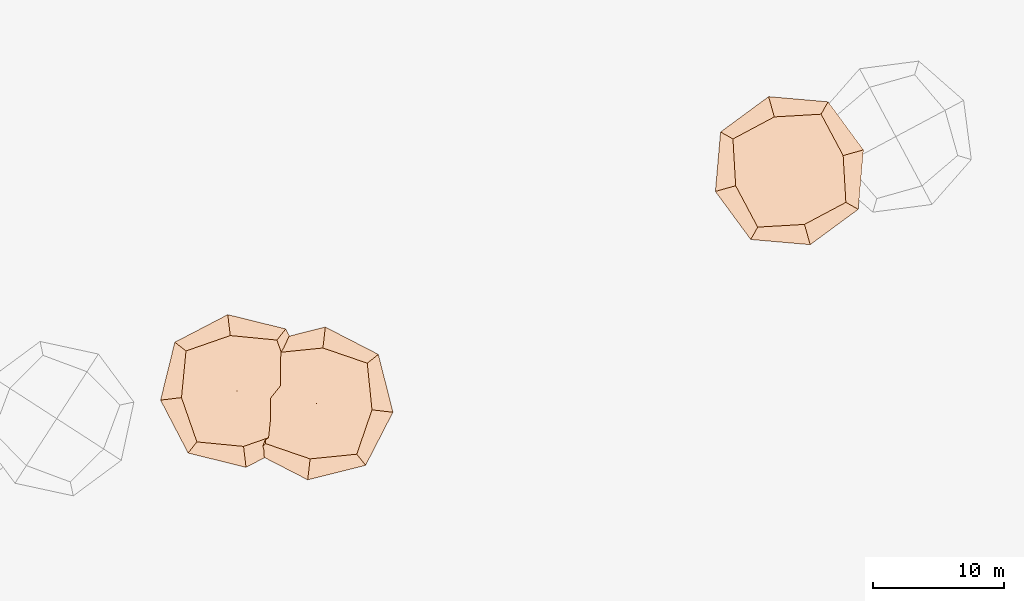
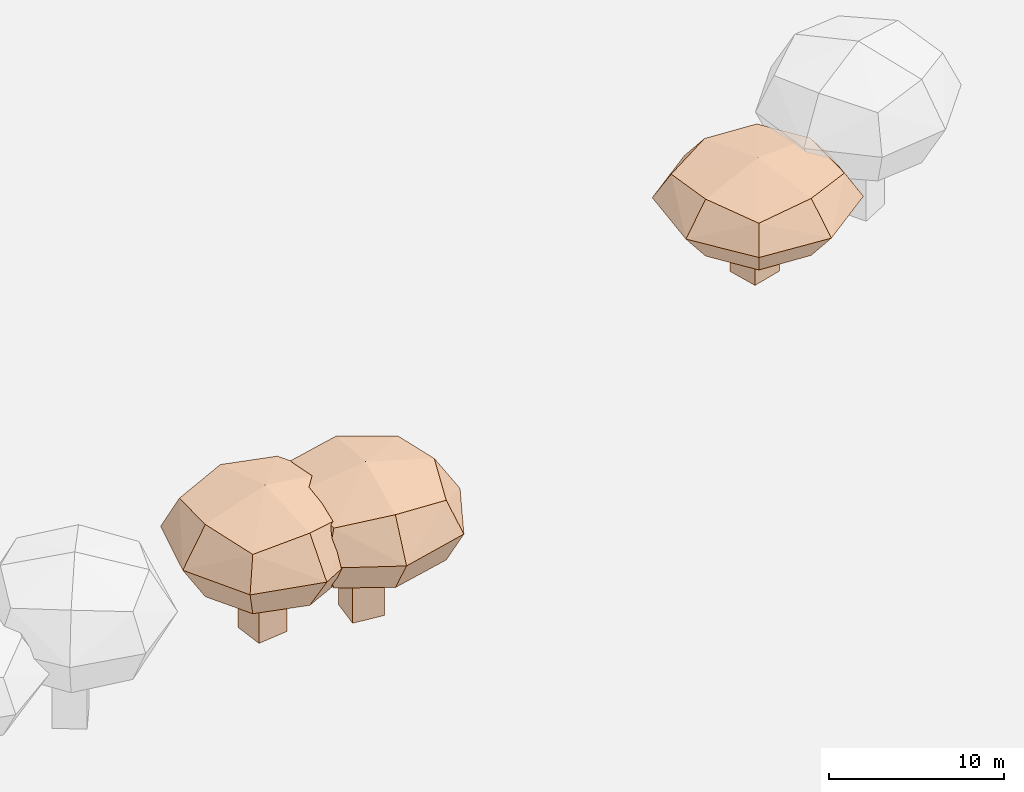
# Not in any storey, part 16 of 92: 3 geographic elements.
"""IFC4 model written with IfcOpenShell, lengths in metres."""

from ifc_helpers import new_model, si_unit, origin_with_axes, place, context, subcontext, project, spatial, triangles, material, element, save


model = new_model("IFC4")

# Units and contexts
model_context = context("Model", 3, precision=1e-05, world=origin_with_axes())
body_context = subcontext(model_context, "Body", "Model", "MODEL_VIEW")
ifc_project = project(units=[si_unit("VOLUMEUNIT", "CUBIC_METRE"), si_unit("LENGTHUNIT", "METRE"), si_unit("AREAUNIT", "SQUARE_METRE")], contexts=[model_context])

# Site
site_placement = place(None, origin_with_axes())
site = spatial("IfcSite", under=ifc_project, at=site_placement)

# Geographic elements
ifc_material = material(Name="tree")
geographic_element_1_placement = place(site_placement, origin_with_axes())
element("IfcGeographicElement", 1, at=geographic_element_1_placement, inside=site, material=ifc_material, Name="cw_instances_tree_207", context=body_context, shape_type="Tessellation", body=[
    triangles([(44.759325062805495, -633.7780550912393, 5.902577090570776), (44.759325062805495, -633.7780550912393, 5.902577090570776), (44.759325062805495, -633.7780550912393, 5.902577090570776), (44.759325062805495, -633.7780550912393, 0.0), (44.759325062805495, -633.7780550912393, 0.0), (44.759325062805495, -633.7780550912393, 0.0), (46.745150937712, -633.5403670718697, 5.902577090570776), (46.745150937712, -633.5403670718697, 5.902577090570776), (46.745150937712, -633.5403670718697, 5.902577090570776), (46.745150937712, -633.5403670718697, 0.0), (46.745150937712, -633.5403670718697, 0.0), (46.745150937712, -633.5403670718697, 0.0), (44.99701308217506, -635.7638809661458, 5.902577090570776), (44.99701308217506, -635.7638809661458, 5.902577090570776), (44.99701308217506, -635.7638809661458, 5.902577090570776), (44.99701308217506, -635.7638809661458, 0.0), (44.99701308217506, -635.7638809661458, 0.0), (44.99701308217506, -635.7638809661458, 0.0), (46.98283895708156, -635.5261929467763, 5.902577090570776), (46.98283895708156, -635.5261929467763, 5.902577090570776), (46.98283895708156, -635.5261929467763, 5.902577090570776), (46.98283895708156, -635.5261929467763, 0.0), (46.98283895708156, -635.5261929467763, 0.0), (46.98283895708156, -635.5261929467763, 0.0), (42.00949515011123, -631.839867910236, 8.792273568300379), (42.00949515011123, -631.839867910236, 8.792273568300379), (42.00949515011123, -631.839867910236, 8.792273568300379), (42.00949515011123, -631.839867910236, 8.792273568300379), (42.00949515011123, -631.839867910236, 8.792273568300379), (42.00949515011123, -631.839867910236, 8.792273568300379), (42.009494644990454, -631.839867728982, 4.6604697701730045), (42.009494644990454, -631.839867728982, 4.6604697701730045), (42.009494644990454, -631.839867728982, 4.6604697701730045), (42.009494644990454, -631.839867728982, 4.6604697701730045), (42.009494644990454, -631.839867728982, 4.6604697701730045), (42.009494644990454, -631.839867728982, 4.6604697701730045), (48.959884025596814, -631.0079598026128, 8.792273568300379), (48.959884025596814, -631.0079598026128, 8.792273568300379), (48.959884025596814, -631.0079598026128, 8.792273568300379), (48.959884025596814, -631.0079598026128, 8.792273568300379), (48.959884025596814, -631.0079598026128, 8.792273568300379), (48.959884025596814, -631.0079598026128, 8.792273568300379), (48.959884025596814, -631.0079598026128, 4.6604697701730045), (48.959884025596814, -631.0079598026128, 4.6604697701730045), (48.959884025596814, -631.0079598026128, 4.6604697701730045), (48.959884025596814, -631.0079598026128, 4.6604697701730045), (48.959884025596814, -631.0079598026128, 4.6604697701730045), (48.959884025596814, -631.0079598026128, 4.6604697701730045), (42.84140265692725, -638.7902578244857, 8.792273568300379), (42.84140265692725, -638.7902578244857, 8.792273568300379), (42.84140265692725, -638.7902578244857, 8.792273568300379), (42.84140265692725, -638.7902578244857, 8.792273568300379), (42.84140265692725, -638.7902578244857, 8.792273568300379), (42.84140265692725, -638.7902578244857, 8.792273568300379), (42.84140259988212, -638.7902573478874, 4.6604697701730045), (42.84140259988212, -638.7902573478874, 4.6604697701730045), (42.84140259988212, -638.7902573478874, 4.6604697701730045), (42.84140259988212, -638.7902573478874, 4.6604697701730045), (42.84140259988212, -638.7902573478874, 4.6604697701730045), (42.84140259988212, -638.7902573478874, 4.6604697701730045), (49.79179227583271, -637.958349869594, 8.792273568300379), (49.79179227583271, -637.958349869594, 8.792273568300379), (49.79179227583271, -637.958349869594, 8.792273568300379), (49.79179227583271, -637.958349869594, 8.792273568300379), (49.79179227583271, -637.958349869594, 8.792273568300379), (49.79179227583271, -637.958349869594, 8.792273568300379), (49.79179203753361, -637.9583498981166, 4.6604697701730045), (49.79179203753361, -637.9583498981166, 4.6604697701730045), (49.79179203753361, -637.9583498981166, 4.6604697701730045), (49.79179203753361, -637.9583498981166, 4.6604697701730045), (49.79179203753361, -637.9583498981166, 4.6604697701730045), (49.79179203753361, -637.9583498981166, 4.6604697701730045), (46.40774785609414, -639.1358431660274, 4.207757367838146), (46.40774785609414, -639.1358431660274, 4.207757367838146), (46.40774785609414, -639.1358431660274, 4.207757367838146), (46.40774785609414, -639.1358431660274, 4.207757367838146), (41.66390955439911, -635.4062130894682, 4.207757367838146), (41.66390955439911, -635.4062130894682, 4.207757367838146), (41.66390955439911, -635.4062130894682, 4.207757367838146), (41.66390955439911, -635.4062130894682, 4.207757367838146), (41.15680523362647, -631.1694792223673, 6.726372023391338), (41.15680523362647, -631.1694792223673, 6.726372023391338), (41.15680523362647, -631.1694792223673, 6.726372023391338), (41.15680523362647, -631.1694792223673, 6.726372023391338), (50.644481743053376, -638.6287388428779, 6.726372023391338), (50.644481743053376, -638.6287388428779, 6.726372023391338), (50.644481743053376, -638.6287388428779, 6.726372023391338), (50.644481743053376, -638.6287388428779, 6.726372023391338), (49.63027344814473, -630.1552700499772, 6.726372023391338), (49.63027344814473, -630.1552700499772, 6.726372023391338), (49.63027344814473, -630.1552700499772, 6.726372023391338), (49.63027344814473, -630.1552700499772, 6.726372023391338), (42.1710138823024, -639.6429470161439, 6.726372023391338), (42.1710138823024, -639.6429470161439, 6.726372023391338), (42.1710138823024, -639.6429470161439, 6.726372023391338), (42.1710138823024, -639.6429470161439, 6.726372023391338), (50.137377824774056, -634.3920043837471, 9.244985616480589), (50.137377824774056, -634.3920043837471, 9.244985616480589), (50.137377824774056, -634.3920043837471, 9.244985616480589), (50.137377824774056, -634.3920043837471, 9.244985616480589), (45.39353899522512, -630.6623744408677, 9.244987003586289), (45.39353899522512, -630.6623744408677, 9.244987003586289), (45.39353899522512, -630.6623744408677, 9.244987003586289), (45.39353899522512, -630.6623744408677, 9.244987003586289), (50.137377364047175, -634.3920044892495, 4.207757367838146), (50.137377364047175, -634.3920044892495, 4.207757367838146), (50.137377364047175, -634.3920044892495, 4.207757367838146), (50.137377364047175, -634.3920044892495, 4.207757367838146), (46.40774781637762, -639.1358431707811, 9.244985616480589), (46.40774781637762, -639.1358431707811, 9.244985616480589), (46.40774781637762, -639.1358431707811, 9.244985616480589), (46.40774781637762, -639.1358431707811, 9.244985616480589), (41.66390955083379, -635.4062130596808, 9.244987003586289), (41.66390955083379, -635.4062130596808, 9.244987003586289), (41.66390955083379, -635.4062130596808, 9.244987003586289), (41.66390955083379, -635.4062130596808, 9.244987003586289), (45.39353911065658, -630.6623749004061, 4.207757367838146), (45.39353911065658, -630.6623749004061, 4.207757367838146), (45.39353911065658, -630.6623749004061, 4.207757367838146), (45.39353911065658, -630.6623749004061, 4.207757367838146), (45.90064331185806, -634.8991088623899, 10.195047334996117), (45.90064331185806, -634.8991088623899, 10.195047334996117), (45.90064331185806, -634.8991088623899, 10.195047334996117), (45.90064331185806, -634.8991088623899, 10.195047334996117), (45.90064331185806, -634.8991088623899, 10.195047334996117), (45.90064331185806, -634.8991088623899, 10.195047334996117), (45.90064331185806, -634.8991088623899, 10.195047334996117), (45.90064331185806, -634.8991088623899, 10.195047334996117), (51.73553835823615, -634.2007169115507, 6.726372023391338), (51.73553835823615, -634.2007169115507, 6.726372023391338), (51.73553835823615, -634.2007169115507, 6.726372023391338), (51.73553835823615, -634.2007169115507, 6.726372023391338), (51.73553835823615, -634.2007169115507, 6.726372023391338), (51.73553835823615, -634.2007169115507, 6.726372023391338), (51.73553835823615, -634.2007169115507, 6.726372023391338), (51.73553835823615, -634.2007169115507, 6.726372023391338), (46.59903529850323, -640.7340037030548, 6.726372023391338), (46.59903529850323, -640.7340037030548, 6.726372023391338), (46.59903529850323, -640.7340037030548, 6.726372023391338), (46.59903529850323, -640.7340037030548, 6.726372023391338), (46.59903529850323, -640.7340037030548, 6.726372023391338), (46.59903529850323, -640.7340037030548, 6.726372023391338), (46.59903529850323, -640.7340037030548, 6.726372023391338), (46.59903529850323, -640.7340037030548, 6.726372023391338), (45.9006432952199, -634.899108723382, 3.257697390582965), (45.9006432952199, -634.899108723382, 3.257697390582965), (45.9006432952199, -634.899108723382, 3.257697390582965), (45.9006432952199, -634.899108723382, 3.257697390582965), (45.9006432952199, -634.899108723382, 3.257697390582965), (45.9006432952199, -634.899108723382, 3.257697390582965), (45.9006432952199, -634.899108723382, 3.257697390582965), (45.9006432952199, -634.899108723382, 3.257697390582965), (45.202251509381426, -629.0642143823937, 6.726372023391338), (45.202251509381426, -629.0642143823937, 6.726372023391338), (45.202251509381426, -629.0642143823937, 6.726372023391338), (45.202251509381426, -629.0642143823937, 6.726372023391338), (45.202251509381426, -629.0642143823937, 6.726372023391338), (45.202251509381426, -629.0642143823937, 6.726372023391338), (45.202251509381426, -629.0642143823937, 6.726372023391338), (45.202251509381426, -629.0642143823937, 6.726372023391338), (40.06574855028101, -635.5975006683555, 6.726372023391338), (40.06574855028101, -635.5975006683555, 6.726372023391338), (40.06574855028101, -635.5975006683555, 6.726372023391338), (40.06574855028101, -635.5975006683555, 6.726372023391338), (40.06574855028101, -635.5975006683555, 6.726372023391338), (40.06574855028101, -635.5975006683555, 6.726372023391338), (40.06574855028101, -635.5975006683555, 6.726372023391338), (40.06574855028101, -635.5975006683555, 6.726372023391338)], [[15, 8, 2], [7, 24, 11], [19, 16, 22], [4, 23, 17], [3, 12, 6], [14, 5, 18], [26, 127, 101], [54, 123, 114], [124, 66, 98], [128, 38, 102], [45, 133, 108], [40, 135, 89], [130, 63, 88], [131, 70, 105], [68, 141, 73], [61, 140, 86], [137, 49, 93], [142, 56, 74], [59, 145, 75], [31, 149, 79], [150, 43, 107], [146, 71, 76], [35, 154, 120], [30, 157, 83], [158, 42, 91], [153, 47, 119], [58, 164, 77], [51, 162, 96], [167, 28, 81], [165, 33, 80], [15, 21, 8], [7, 20, 24], [19, 13, 16], [4, 10, 23], [3, 9, 12], [14, 1, 5], [25, 115, 126], [53, 111, 121], [122, 112, 65], [125, 99, 37], [46, 90, 136], [39, 100, 134], [132, 97, 64], [129, 87, 69], [67, 85, 138], [62, 110, 144], [143, 109, 50], [139, 94, 55], [60, 78, 147], [32, 117, 151], [152, 118, 44], [148, 106, 72], [36, 84, 160], [29, 104, 156], [155, 103, 41], [159, 92, 48], [57, 95, 161], [52, 113, 163], [166, 116, 27], [168, 82, 34]], closed=True),
])
geographic_element_2_placement = place(site_placement, origin_with_axes())
element("IfcGeographicElement", 2, at=geographic_element_2_placement, inside=site, material=ifc_material, Name="cw_instances_tree_208", context=body_context, shape_type="Tessellation", body=[
    triangles([(50.63154918555247, -636.7017609401604, 5.952848549605816), (50.63154918555247, -636.7017609401604, 5.952848549605816), (50.63154918555247, -636.7017609401604, 5.952848549605816), (50.63154918555247, -636.7017609401604, 0.0), (50.63154918555247, -636.7017609401604, 0.0), (50.63154918555247, -636.7017609401604, 0.0), (50.860824018427174, -634.7149461397801, 5.952848549605816), (50.860824018427174, -634.7149461397801, 5.952848549605816), (50.860824018427174, -634.7149461397801, 5.952848549605816), (50.860824018427174, -634.7149461397801, 0.0), (50.860824018427174, -634.7149461397801, 0.0), (50.860824018427174, -634.7149461397801, 0.0), (52.61836398593279, -636.9310357730351, 5.952848549605816), (52.61836398593279, -636.9310357730351, 5.952848549605816), (52.61836398593279, -636.9310357730351, 5.952848549605816), (52.61836398593279, -636.9310357730351, 0.0), (52.61836398593279, -636.9310357730351, 0.0), (52.61836398593279, -636.9310357730351, 0.0), (52.847638818807496, -634.9442209726548, 5.952848549605816), (52.847638818807496, -634.9442209726548, 5.952848549605816), (52.847638818807496, -634.9442209726548, 5.952848549605816), (52.847638818807496, -634.9442209726548, 0.0), (52.847638818807496, -634.9442209726548, 0.0), (52.847638818807496, -634.9442209726548, 0.0), (48.108545335083626, -638.9272014960669, 8.867156185457514), (48.108545335083626, -638.9272014960669, 8.867156185457514), (48.108545335083626, -638.9272014960669, 8.867156185457514), (48.108545335083626, -638.9272014960669, 8.867156185457514), (48.108545335083626, -638.9272014960669, 8.867156185457514), (48.108545335083626, -638.9272014960669, 8.867156185457514), (48.10854504163989, -638.9272019453895, 4.700162367413212), (48.10854504163989, -638.9272019453895, 4.700162367413212), (48.10854504163989, -638.9272019453895, 4.700162367413212), (48.10854504163989, -638.9272019453895, 4.700162367413212), (48.10854504163989, -638.9272019453895, 4.700162367413212), (48.10854504163989, -638.9272019453895, 4.700162367413212), (48.91100682028282, -631.9733513262131, 8.867156185457514), (48.91100682028282, -631.9733513262131, 8.867156185457514), (48.91100682028282, -631.9733513262131, 8.867156185457514), (48.91100682028282, -631.9733513262131, 8.867156185457514), (48.91100682028282, -631.9733513262131, 8.867156185457514), (48.91100682028282, -631.9733513262131, 8.867156185457514), (48.91100682028282, -631.9733513262131, 4.700162367413212), (48.91100682028282, -631.9733513262131, 4.700162367413212), (48.91100682028282, -631.9733513262131, 4.700162367413212), (48.91100682028282, -631.9733513262131, 4.700162367413212), (48.91100682028282, -631.9733513262131, 4.700162367413212), (48.91100682028282, -631.9733513262131, 4.700162367413212), (55.06239637606952, -639.7296638065714, 8.867156185457514), (55.06239637606952, -639.7296638065714, 8.867156185457514), (55.06239637606952, -639.7296638065714, 8.867156185457514), (55.06239637606952, -639.7296638065714, 8.867156185457514), (55.06239637606952, -639.7296638065714, 8.867156185457514), (55.06239637606952, -639.7296638065714, 8.867156185457514), (55.06239589923397, -639.7296637515453, 4.700162367413212), (55.06239589923397, -639.7296637515453, 4.700162367413212), (55.06239589923397, -639.7296637515453, 4.700162367413212), (55.06239589923397, -639.7296637515453, 4.700162367413212), (55.06239589923397, -639.7296637515453, 4.700162367413212), (55.06239589923397, -639.7296637515453, 4.700162367413212), (55.86485818222543, -632.7758129489772, 8.867156185457514), (55.86485818222543, -632.7758129489772, 8.867156185457514), (55.86485818222543, -632.7758129489772, 8.867156185457514), (55.86485818222543, -632.7758129489772, 8.867156185457514), (55.86485818222543, -632.7758129489772, 8.867156185457514), (55.86485818222543, -632.7758129489772, 8.867156185457514), (55.86485815471245, -632.775813187395, 4.700162367413212), (55.86485815471245, -632.775813187395, 4.700162367413212), (55.86485815471245, -632.775813187395, 4.700162367413212), (55.86485815471245, -632.775813187395, 4.700162367413212), (55.86485815471245, -632.775813187395, 4.700162367413212), (55.86485815471245, -632.775813187395, 4.700162367413212), (56.22554584215529, -636.3406623861742, 4.243594274142103), (56.22554584215529, -636.3406623861742, 4.243594274142103), (56.22554584215529, -636.3406623861742, 4.243594274142103), (56.22554584215529, -636.3406623861742, 4.243594274142103), (51.49754667715101, -640.0903512047727, 4.243594274142103), (51.49754667715101, -640.0903512047727, 4.243594274142103), (51.49754667715101, -640.0903512047727, 4.243594274142103), (51.49754667715101, -640.0903512047727, 4.243594274142103), (47.25870295031868, -639.6011963087725, 6.783659633606297), (47.25870295031868, -639.6011963087725, 6.783659633606297), (47.25870295031868, -639.6011963087725, 6.783659633606297), (47.25870295031868, -639.6011963087725, 6.783659633606297), (56.71470074044812, -632.1018186394738, 6.783659633606297), (56.71470074044812, -632.1018186394738, 6.783659633606297), (56.71470074044812, -632.1018186394738, 6.783659633606297), (56.71470074044812, -632.1018186394738, 6.783659633606297), (48.23701233732157, -631.1235082647883, 6.783659633606297), (48.23701233732157, -631.1235082647883, 6.783659633606297), (48.23701233732157, -631.1235082647883, 6.783659633606297), (48.23701233732157, -631.1235082647883, 6.783659633606297), (55.73639046358778, -640.5795061076509, 6.783659633606297), (55.73639046358778, -640.5795061076509, 6.783659633606297), (55.73639046358778, -640.5795061076509, 6.783659633606297), (55.73639046358778, -640.5795061076509, 6.783659633606297), (52.475856531055385, -631.6126632146679, 9.323723921557686), (52.475856531055385, -631.6126632146679, 9.323723921557686), (52.475856531055385, -631.6126632146679, 9.323723921557686), (52.475856531055385, -631.6126632146679, 9.323723921557686), (47.74785737368541, -635.362352577731, 9.32372532047718), (47.74785737368541, -635.362352577731, 9.32372532047718), (47.74785737368541, -635.362352577731, 9.32372532047718), (47.74785737368541, -635.362352577731, 9.32372532047718), (52.475856526846165, -631.6126636873013, 4.243594274142103), (52.475856526846165, -631.6126636873013, 4.243594274142103), (52.475856526846165, -631.6126636873013, 4.243594274142103), (52.475856526846165, -631.6126636873013, 4.243594274142103), (56.2255458375698, -636.3406624259105, 9.323723921557686), (56.2255458375698, -636.3406624259105, 9.323723921557686), (56.2255458375698, -636.3406624259105, 9.323723921557686), (56.2255458375698, -636.3406624259105, 9.323723921557686), (51.497546647348784, -640.0903512013335, 9.32372532047718), (51.497546647348784, -640.0903512013335, 9.32372532047718), (51.497546647348784, -640.0903512013335, 9.32372532047718), (51.497546647348784, -640.0903512013335, 9.32372532047718), (47.747857847465134, -635.3623525720061, 4.243594274142103), (47.747857847465134, -635.3623525720061, 4.243594274142103), (47.747857847465134, -635.3623525720061, 4.243594274142103), (47.747857847465134, -635.3623525720061, 4.243594274142103), (51.986701638867196, -635.8515076063202, 10.2818771885664), (51.986701638867196, -635.8515076063202, 10.2818771885664), (51.986701638867196, -635.8515076063202, 10.2818771885664), (51.986701638867196, -635.8515076063202, 10.2818771885664), (51.986701638867196, -635.8515076063202, 10.2818771885664), (51.986701638867196, -635.8515076063202, 10.2818771885664), (51.986701638867196, -635.8515076063202, 10.2818771885664), (51.986701638867196, -635.8515076063202, 10.2818771885664), (52.66037320688615, -630.0137068099854, 6.783659633606297), (52.66037320688615, -630.0137068099854, 6.783659633606297), (52.66037320688615, -630.0137068099854, 6.783659633606297), (52.66037320688615, -630.0137068099854, 6.783659633606297), (52.66037320688615, -630.0137068099854, 6.783659633606297), (52.66037320688615, -630.0137068099854, 6.783659633606297), (52.66037320688615, -630.0137068099854, 6.783659633606297), (52.66037320688615, -630.0137068099854, 6.783659633606297), (57.824502243398776, -636.5251790918072, 6.783659633606297), (57.824502243398776, -636.5251790918072, 6.783659633606297), (57.824502243398776, -636.5251790918072, 6.783659633606297), (57.824502243398776, -636.5251790918072, 6.783659633606297), (57.824502243398776, -636.5251790918072, 6.783659633606297), (57.824502243398776, -636.5251790918072, 6.783659633606297), (57.824502243398776, -636.5251790918072, 6.783659633606297), (57.824502243398776, -636.5251790918072, 6.783659633606297), (51.98670149979016, -635.8515075902709, 3.2854427632238186), (51.98670149979016, -635.8515075902709, 3.2854427632238186), (51.98670149979016, -635.8515075902709, 3.2854427632238186), (51.98670149979016, -635.8515075902709, 3.2854427632238186), (51.98670149979016, -635.8515075902709, 3.2854427632238186), (51.98670149979016, -635.8515075902709, 3.2854427632238186), (51.98670149979016, -635.8515075902709, 3.2854427632238186), (51.98670149979016, -635.8515075902709, 3.2854427632238186), (46.148901427879665, -635.1778360253184, 6.783659633606297), (46.148901427879665, -635.1778360253184, 6.783659633606297), (46.148901427879665, -635.1778360253184, 6.783659633606297), (46.148901427879665, -635.1778360253184, 6.783659633606297), (46.148901427879665, -635.1778360253184, 6.783659633606297), (46.148901427879665, -635.1778360253184, 6.783659633606297), (46.148901427879665, -635.1778360253184, 6.783659633606297), (46.148901427879665, -635.1778360253184, 6.783659633606297), (51.313029995964655, -641.6893080920227, 6.783659633606297), (51.313029995964655, -641.6893080920227, 6.783659633606297), (51.313029995964655, -641.6893080920227, 6.783659633606297), (51.313029995964655, -641.6893080920227, 6.783659633606297), (51.313029995964655, -641.6893080920227, 6.783659633606297), (51.313029995964655, -641.6893080920227, 6.783659633606297), (51.313029995964655, -641.6893080920227, 6.783659633606297), (51.313029995964655, -641.6893080920227, 6.783659633606297)], [[15, 8, 2], [7, 24, 11], [19, 16, 22], [4, 23, 17], [3, 12, 6], [14, 5, 18], [26, 127, 101], [54, 123, 114], [124, 66, 98], [128, 38, 102], [45, 133, 108], [40, 135, 89], [130, 63, 88], [131, 70, 105], [68, 141, 73], [61, 140, 86], [137, 49, 93], [142, 56, 74], [59, 145, 75], [31, 149, 79], [150, 43, 107], [146, 71, 76], [35, 154, 120], [30, 157, 83], [158, 42, 91], [153, 47, 119], [58, 164, 77], [51, 162, 96], [167, 28, 81], [165, 33, 80], [15, 21, 8], [7, 20, 24], [19, 13, 16], [4, 10, 23], [3, 9, 12], [14, 1, 5], [25, 115, 126], [53, 111, 121], [122, 112, 65], [125, 99, 37], [46, 90, 136], [39, 100, 134], [132, 97, 64], [129, 87, 69], [67, 85, 138], [62, 110, 144], [143, 109, 50], [139, 94, 55], [60, 78, 147], [32, 117, 151], [152, 118, 44], [148, 106, 72], [36, 84, 160], [29, 104, 156], [155, 103, 41], [159, 92, 48], [57, 95, 161], [52, 113, 163], [166, 116, 27], [168, 82, 34]], closed=True),
])
geographic_element_3_placement = place(site_placement, origin_with_axes())
element("IfcGeographicElement", 3, at=geographic_element_3_placement, inside=site, material=ifc_material, Name="cw_instances_tree_209", context=body_context, shape_type="Tessellation", body=[
    triangles([(86.83109283719733, -617.1259235911157, 4.653838994288196), (86.83109283719733, -617.1259235911157, 4.653838994288196), (86.83109283719733, -617.1259235911157, 4.653838994288196), (86.83109283719733, -617.1259235911157, 0.0), (86.83109283719733, -617.1259235911157, 0.0), (86.83109283719733, -617.1259235911157, 0.0), (88.75665702262802, -616.5853659459134, 4.653838994288196), (88.75665702262802, -616.5853659459134, 4.653838994288196), (88.75665702262802, -616.5853659459134, 4.653838994288196), (88.75665702262802, -616.5853659459134, 0.0), (88.75665702262802, -616.5853659459134, 0.0), (88.75665702262802, -616.5853659459134, 0.0), (87.37165048239963, -619.0514877765463, 4.653838994288196), (87.37165048239963, -619.0514877765463, 4.653838994288196), (87.37165048239963, -619.0514877765463, 4.653838994288196), (87.37165048239963, -619.0514877765463, 0.0), (87.37165048239963, -619.0514877765463, 0.0), (87.37165048239963, -619.0514877765463, 0.0), (89.29721466783032, -618.510930131344, 4.653838994288196), (89.29721466783032, -618.510930131344, 4.653838994288196), (89.29721466783032, -618.510930131344, 4.653838994288196), (89.29721466783032, -618.510930131344, 0.0), (89.29721466783032, -618.510930131344, 0.0), (89.29721466783032, -618.510930131344, 0.0), (83.81567211275492, -615.6341555287289, 6.932196725726965), (83.81567211275492, -615.6341555287289, 6.932196725726965), (83.81567211275492, -615.6341555287289, 6.932196725726965), (83.81567211275492, -615.6341555287289, 6.932196725726965), (83.81567211275492, -615.6341555287289, 6.932196725726965), (83.81567211275492, -615.6341555287289, 6.932196725726965), (83.8156715857526, -615.6341554273951, 3.674509560032727), (83.8156715857526, -615.6341554273951, 3.674509560032727), (83.8156715857526, -615.6341554273951, 3.674509560032727), (83.8156715857526, -615.6341554273951, 3.674509560032727), (83.8156715857526, -615.6341554273951, 3.674509560032727), (83.8156715857526, -615.6341554273951, 3.674509560032727), (90.5551450890493, -613.7422039908188, 6.932196725726965), (90.5551450890493, -613.7422039908188, 6.932196725726965), (90.5551450890493, -613.7422039908188, 6.932196725726965), (90.5551450890493, -613.7422039908188, 6.932196725726965), (90.5551450890493, -613.7422039908188, 6.932196725726965), (90.5551450890493, -613.7422039908188, 6.932196725726965), (90.5551450890493, -613.7422039908188, 3.674509560032727), (90.5551450890493, -613.7422039908188, 3.674509560032727), (90.5551450890493, -613.7422039908188, 3.674509560032727), (90.5551450890493, -613.7422039908188, 3.674509560032727), (90.5551450890493, -613.7422039908188, 3.674509560032727), (90.5551450890493, -613.7422039908188, 3.674509560032727), (85.7076232169296, -622.3736296238949, 6.932196725726965), (85.7076232169296, -622.3736296238949, 6.932196725726965), (85.7076232169296, -622.3736296238949, 6.932196725726965), (85.7076232169296, -622.3736296238949, 6.932196725726965), (85.7076232169296, -622.3736296238949, 6.932196725726965), (85.7076232169296, -622.3736296238949, 6.932196725726965), (85.70762308719577, -622.3736291617595, 3.674509560032727), (85.70762308719577, -622.3736291617595, 3.674509560032727), (85.70762308719577, -622.3736291617595, 3.674509560032727), (85.70762308719577, -622.3736291617595, 3.674509560032727), (85.70762308719577, -622.3736291617595, 3.674509560032727), (85.70762308719577, -622.3736291617595, 3.674509560032727), (92.44709695129401, -620.4816781224517, 6.932196725726965), (92.44709695129401, -620.4816781224517, 6.932196725726965), (92.44709695129401, -620.4816781224517, 6.932196725726965), (92.44709695129401, -620.4816781224517, 6.932196725726965), (92.44709695129401, -620.4816781224517, 6.932196725726965), (92.44709695129401, -620.4816781224517, 6.932196725726965), (92.44709672022631, -620.4816781873186, 3.674509560032727), (92.44709672022631, -620.4816781873186, 3.674509560032727), (92.44709672022631, -620.4816781873186, 3.674509560032727), (92.44709672022631, -620.4816781873186, 3.674509560032727), (92.44709672022631, -620.4816781873186, 3.674509560032727), (92.44709672022631, -620.4816781873186, 3.674509560032727), (89.28465717689576, -622.1660835876569, 3.317572141197572), (89.28465717689576, -622.1660835876569, 3.317572141197572), (89.28465717689576, -622.1660835876569, 3.317572141197572), (89.28465717689576, -622.1660835876569, 3.317572141197572), (84.02321789478344, -619.2111895081257, 3.317572141197572), (84.02321789478344, -619.2111895081257, 3.317572141197572), (84.02321789478344, -619.2111895081257, 3.317572141197572), (84.02321789478344, -619.2111895081257, 3.317572141197572), (82.86994513734354, -615.1030231775429, 5.303353422110202), (82.86994513734354, -615.1030231775429, 5.303353422110202), (82.86994513734354, -615.1030231775429, 5.303353422110202), (82.86994513734354, -615.1030231775429, 5.303353422110202), (93.39282352673413, -621.0128108248115, 5.303353422110202), (93.39282352673413, -621.0128108248115, 5.303353422110202), (93.39282352673413, -621.0128108248115, 5.303353422110202), (93.39282352673413, -621.0128108248115, 5.303353422110202), (91.08627819138029, -612.796477064205, 5.303353422110202), (91.08627819138029, -612.796477064205, 5.303353422110202), (91.08627819138029, -612.796477064205, 5.303353422110202), (91.08627819138029, -612.796477064205, 5.303353422110202), (85.17649066844008, -623.3193558964754, 5.303353422110202), (85.17649066844008, -623.3193558964754, 5.303353422110202), (85.17649066844008, -623.3193558964754, 5.303353422110202), (85.17649066844008, -623.3193558964754, 5.303353422110202), (92.23955107585124, -616.9046438472953, 7.289133865331762), (92.23955107585124, -616.9046438472953, 7.289133865331762), (92.23955107585124, -616.9046438472953, 7.289133865331762), (92.23955107585124, -616.9046438472953, 7.289133865331762), (86.97811129275611, -613.9497499811094, 7.289134958983992), (86.97811129275611, -613.9497499811094, 7.289134958983992), (86.97811129275611, -613.9497499811094, 7.289134958983992), (86.97811129275611, -613.9497499811094, 7.289134958983992), (92.2395506368576, -616.9046440224655, 3.317572141197572), (92.2395506368576, -616.9046440224655, 3.317572141197572), (92.2395506368576, -616.9046440224655, 3.317572141197572), (92.2395506368576, -616.9046440224655, 3.317572141197572), (89.28465713838447, -622.166083598468, 7.289133865331762), (89.28465713838447, -622.166083598468, 7.289133865331762), (89.28465713838447, -622.166083598468, 7.289133865331762), (89.28465713838447, -622.166083598468, 7.289133865331762), (84.02321788667507, -619.2111894792422, 7.289134958983992), (84.02321788667507, -619.2111894792422, 7.289134958983992), (84.02321788667507, -619.2111894792422, 7.289134958983992), (84.02321788667507, -619.2111894792422, 7.289134958983992), (86.97811147755408, -613.9497504174003, 3.317572141197572), (86.97811147755408, -613.9497504174003, 3.317572141197572), (86.97811147755408, -613.9497504174003, 3.317572141197572), (86.97811147755408, -613.9497504174003, 3.317572141197572), (88.13138413145464, -618.0579168601419, 8.03820231539422), (88.13138413145464, -618.0579168601419, 8.03820231539422), (88.13138413145464, -618.0579168601419, 8.03820231539422), (88.13138413145464, -618.0579168601419, 8.03820231539422), (88.13138413145464, -618.0579168601419, 8.03820231539422), (88.13138413145464, -618.0579168601419, 8.03820231539422), (88.13138413145464, -618.0579168601419, 8.03820231539422), (88.13138413145464, -618.0579168601419, 8.03820231539422), (93.78921397665734, -616.4696118006592, 5.303353422110202), (93.78921397665734, -616.4696118006592, 5.303353422110202), (93.78921397665734, -616.4696118006592, 5.303353422110202), (93.78921397665734, -616.4696118006592, 5.303353422110202), (93.78921397665734, -616.4696118006592, 5.303353422110202), (93.78921397665734, -616.4696118006592, 5.303353422110202), (93.78921397665734, -616.4696118006592, 5.303353422110202), (93.78921397665734, -616.4696118006592, 5.303353422110202), (89.71968919464841, -623.7157464965713, 5.303353422110202), (89.71968919464841, -623.7157464965713, 5.303353422110202), (89.71968919464841, -623.7157464965713, 5.303353422110202), (89.71968919464841, -623.7157464965713, 5.303353422110202), (89.71968919464841, -623.7157464965713, 5.303353422110202), (89.71968919464841, -623.7157464965713, 5.303353422110202), (89.71968919464841, -623.7157464965713, 5.303353422110202), (89.71968919464841, -623.7157464965713, 5.303353422110202), (88.1313840936156, -618.0579167253524, 2.568505064017701), (88.1313840936156, -618.0579167253524, 2.568505064017701), (88.1313840936156, -618.0579167253524, 2.568505064017701), (88.1313840936156, -618.0579167253524, 2.568505064017701), (88.1313840936156, -618.0579167253524, 2.568505064017701), (88.1313840936156, -618.0579167253524, 2.568505064017701), (88.1313840936156, -618.0579167253524, 2.568505064017701), (88.1313840936156, -618.0579167253524, 2.568505064017701), (86.5430793057563, -612.4000875517304, 5.303353422110202), (86.5430793057563, -612.4000875517304, 5.303353422110202), (86.5430793057563, -612.4000875517304, 5.303353422110202), (86.5430793057563, -612.4000875517304, 5.303353422110202), (86.5430793057563, -612.4000875517304, 5.303353422110202), (86.5430793057563, -612.4000875517304, 5.303353422110202), (86.5430793057563, -612.4000875517304, 5.303353422110202), (86.5430793057563, -612.4000875517304, 5.303353422110202), (82.47355454535588, -619.6462217326348, 5.303353422110202), (82.47355454535588, -619.6462217326348, 5.303353422110202), (82.47355454535588, -619.6462217326348, 5.303353422110202), (82.47355454535588, -619.6462217326348, 5.303353422110202), (82.47355454535588, -619.6462217326348, 5.303353422110202), (82.47355454535588, -619.6462217326348, 5.303353422110202), (82.47355454535588, -619.6462217326348, 5.303353422110202), (82.47355454535588, -619.6462217326348, 5.303353422110202)], [[15, 8, 2], [7, 24, 11], [19, 16, 22], [4, 23, 17], [3, 12, 6], [14, 5, 18], [26, 127, 101], [54, 123, 114], [124, 66, 98], [128, 38, 102], [45, 133, 108], [40, 135, 89], [130, 63, 88], [131, 70, 105], [68, 141, 73], [61, 140, 86], [137, 49, 93], [142, 56, 74], [59, 145, 75], [31, 149, 79], [150, 43, 107], [146, 71, 76], [35, 154, 120], [30, 157, 83], [158, 42, 91], [153, 47, 119], [58, 164, 77], [51, 162, 96], [167, 28, 81], [165, 33, 80], [15, 21, 8], [7, 20, 24], [19, 13, 16], [4, 10, 23], [3, 9, 12], [14, 1, 5], [25, 115, 126], [53, 111, 121], [122, 112, 65], [125, 99, 37], [46, 90, 136], [39, 100, 134], [132, 97, 64], [129, 87, 69], [67, 85, 138], [62, 110, 144], [143, 109, 50], [139, 94, 55], [60, 78, 147], [32, 117, 151], [152, 118, 44], [148, 106, 72], [36, 84, 160], [29, 104, 156], [155, 103, 41], [159, 92, 48], [57, 95, 161], [52, 113, 163], [166, 116, 27], [168, 82, 34]], closed=True),
])

save(model, "model.ifc")
